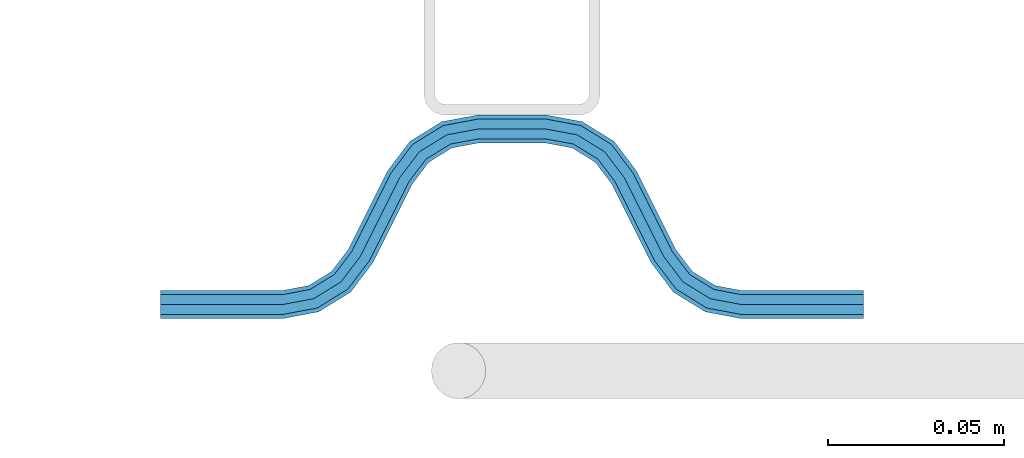
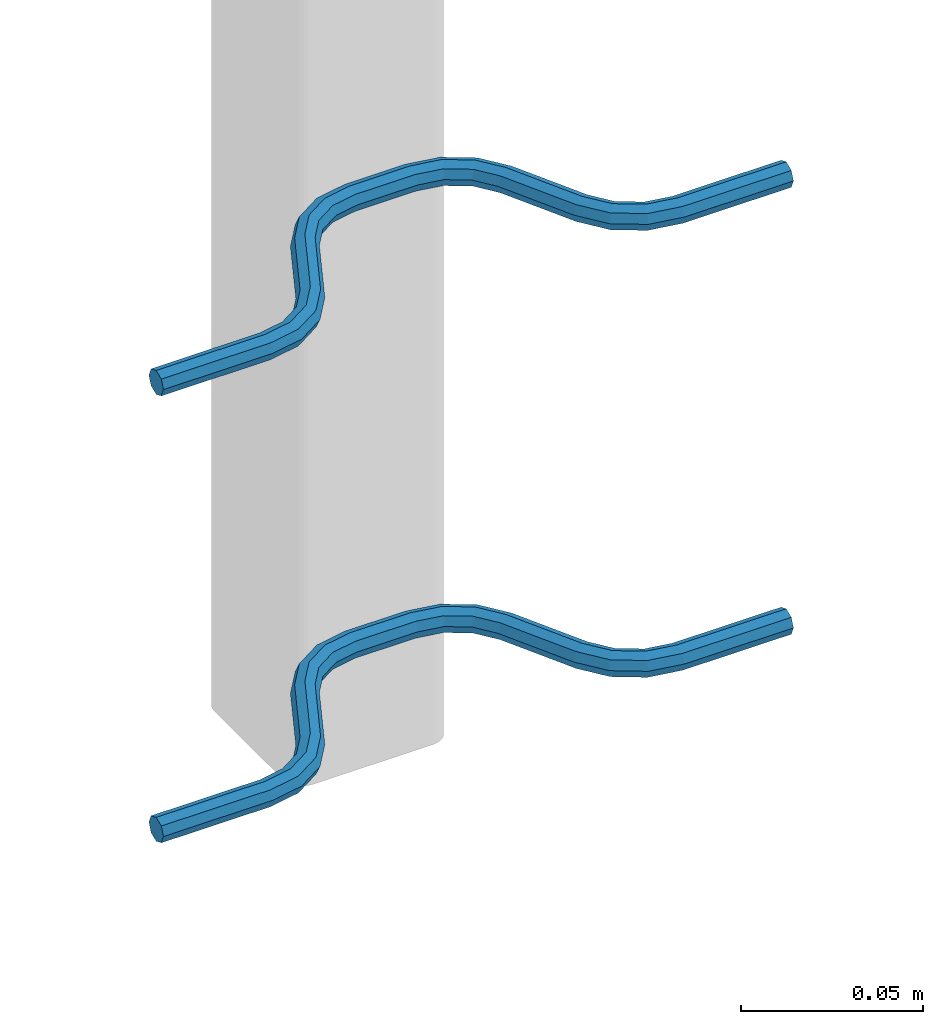
# One storey, part 5 of 5: 2 beams, 2 elements without a shape of their own.
"""IFC2X3 building model written with IfcOpenShell, lengths in millimetres."""

from ifc_helpers import new_model, si_unit, frame, origin_with_axes, place, context, subcontext, project, spatial, faceted_brep, material, type_object, element, aggregate, save


model = new_model("IFC2X3")

# Units and contexts
model_context = context("Model", 3, precision=1e-05, world=origin_with_axes())
body_context = subcontext(model_context, "Body", "Model", "MODEL_VIEW")
ifc_project = project(units=[si_unit("LENGTHUNIT", "METRE", prefix="MILLI"), si_unit("AREAUNIT", "SQUARE_METRE"), si_unit("VOLUMEUNIT", "CUBIC_METRE"), si_unit("MASSUNIT", "GRAM", prefix="KILO"), si_unit("TIMEUNIT", "SECOND"), si_unit("PLANEANGLEUNIT", "RADIAN"), si_unit("SOLIDANGLEUNIT", "STERADIAN"), si_unit("THERMODYNAMICTEMPERATUREUNIT", "DEGREE_CELSIUS"), si_unit("LUMINOUSINTENSITYUNIT", "LUMEN")], contexts=[model_context])

# Site, building, storey
site_placement = place(None, origin_with_axes())
site = spatial("IfcSite", under=ifc_project, at=site_placement, CompositionType="ELEMENT")
building_placement = place(site_placement, origin_with_axes())
building = spatial("IfcBuilding", under=site, at=building_placement, Name="Undefined", CompositionType="ELEMENT")
storey_placement = place(building_placement, origin_with_axes())
storey = spatial("IfcBuildingStorey", under=building, at=storey_placement, Name="Undefined", CompositionType="ELEMENT", Elevation=0.0)

# Assembly, beam
assembly_1_placement = place(storey_placement, origin_with_axes())
assembly_1 = element("IfcElementAssembly", 1, at=assembly_1_placement, inside=storey, Name="Steel Assembly", AssemblyPlace="NOTDEFINED", PredefinedType="NOTDEFINED")
ifc_material = material(Name="REBAR/A500HW")
beam_type = type_object("IfcBeamType", Name="D8", PredefinedType="NOTDEFINED")
beam_1_placement = place(assembly_1_placement, frame((38620.0028939469, 7595.92038402465, 2580.99992151562), z_axis=(0.0, 0.0, 1.0), x_axis=(-0.999999999544916, 3.01690000135643e-05, 0.0)))
beam_1 = element("IfcBeam", 2, at=beam_1_placement, type_object=beam_type, material=ifc_material, Name="AnchorRebar", ObjectType="D8", context=body_context, shape_type="Brep", body=[
    faceted_brep([(7.27595761418343e-12, -4.00000000000182, 0.0), (0.0, -2.82842712474667, -2.82842712474621), (34.5491497807379, -2.82842712464299, -2.82842712474621), (34.549149780345, -3.99999999990087, 0.0), (-7.27595761418343e-12, -1.81898940354586e-12, -4.0), (34.5491497807307, 1.02772901300341e-10, -4.0), (-1.45519152283669e-11, 2.82842712474485, -2.82842712474621), (34.5491497807234, 2.82842712484944, -2.82842712474621), (-2.18278728425503e-11, 3.99999999999909, 0.0), (34.5491497807234, 4.00000000010186, 0.0), (-1.45519152283669e-11, 2.82842712474485, 2.82842712474621), (34.5491497807234, 2.82842712484944, 2.82842712474621), (-7.27595761418343e-12, -1.81898940354586e-12, 4.0), (34.5491497807307, 1.02772901300341e-10, 4.0), (0.0, -2.82842712474667, 2.82842712474621), (34.5491497807379, -2.82842712464299, 2.82842712474621), (45.0102956729243, 2.04744769147965, 0.0), (44.5876751635515, 0.954756103194086, -2.82842712474621), (43.5673789981083, -1.68323474872432, -4.0), (42.5470828326725, -4.32122560063453, -2.82842712474621), (42.1244623233069, -5.41391718891373, 0.0), (42.5470828326725, -4.32122560063453, 2.82842712474621), (43.5673789981083, -1.68323474872432, 4.0), (44.5876751635515, 0.954756103194086, 2.82842712474621), (53.274424966643, -4.41395070837552, 2.82842712474621), (54.0627564232345, -3.54728092317691, 0.0), (51.3712244724884, -6.50627665790307, 4.0), (49.4680239783338, -8.59860260741789, 2.82842712474621), (48.6796925217277, -9.46527239261468, 0.0), (49.4680239783338, -8.59860260741789, -2.82842712474621), (51.3712244724884, -6.50627665790307, -4.0), (53.274424966643, -4.41395070837552, -2.82842712474621), (59.4396520594746, -12.5547498008682, 2.82842712474621), (60.4875387111679, -12.0308065146201, 0.0), (56.9098298930985, -13.8196607884374, 4.0), (54.3800077267297, -15.0845717760067, 2.82842712474621), (53.3321210758731, -15.6085150625322, 0.0), (54.3800077267297, -15.0845717760067, -2.82842712474621), (56.9098298930985, -13.8196607884374, -4.0), (59.4396520594746, -12.5547498008682, -2.82842712474621), (65.5603461600622, -37.4452503321163, -2.82842712474621), (64.5124595074158, -37.9691936177969, 0.0), (68.0901683264528, -36.1803393445689, -4.0), (70.6199904928435, -34.9154283570224, -2.82842712474621), (71.6678771445659, -34.3914850707852, 0.0), (70.6199904928435, -34.9154283570224, 2.82842712474621), (68.0901683264528, -36.1803393445689, 4.0), (65.5603461600622, -37.4452503321163, 2.82842712474621), (76.3203054721671, -40.5347275358472, 0.0), (75.5319740029881, -41.4013973096107, -2.82842712474621), (73.6287734785001, -43.493723231526, -4.0), (71.725572954012, -45.5860491534477, -2.82842712474621), (70.9372414848403, -46.4527189272058, 0.0), (71.725572954012, -45.5860491534477, 2.82842712474621), (73.6287734785001, -43.493723231526, 4.0), (75.5319740029881, -41.4013973096107, 2.82842712474621), (82.4529147876383, -45.678774301171, 2.82842712474621), (82.8755353286615, -44.5860827251427, 0.0), (81.4326185457467, -48.316765123519, 4.0), (80.4123223038623, -50.9547559458688, 2.82842712474621), (79.9897017628464, -52.0474475218998, 0.0), (80.4123223038623, -50.9547559458688, -2.82842712474621), (81.4326185457467, -48.316765123519, -4.0), (82.4529147876383, -45.678774301171, -2.82842712474621), (90.4508474761824, -47.1715730089909, 2.82842712474621), (90.4508475270486, -46.0000001337403, 0.0), (90.4508473533569, -50.0000001337421, 4.0), (90.4508472305388, -52.8284272584824, 2.82842712474621), (90.4508471810623, -54.0000001334192, 0.0), (90.4508472305388, -52.8284272584824, -2.82842712474621), (90.4508473533569, -50.0000001337421, -4.0), (90.4508474761824, -47.1715730089909, -2.82842712474621), (109.549147671314, -52.828428087013, -2.82842712474621), (109.549147618898, -54.0000009615114, 0.0), (109.549147794067, -50.0000009622654, -4.0), (109.549147916819, -47.1715738375196, -2.82842712474621), (109.549147967664, -46.0000009622663, 0.0), (109.549147916819, -47.1715738375196, 2.82842712474621), (109.549147794067, -50.0000009622654, 4.0), (109.549147671314, -52.828428087013, 2.82842712474621), (120.010293517989, -52.0474491371906, 0.0), (119.587673059206, -50.95475752935, 2.82842712474621), (118.567377015956, -48.3167666302052, 4.0), (117.547080972676, -45.6787757310622, 2.82842712474621), (117.124460513907, -44.5860841232252, 0.0), (117.547080972676, -45.6787757310622, -2.82842712474621), (118.567377015956, -48.3167666302052, -4.0), (119.587673059206, -50.95475752935, -2.82842712474621), (128.274423051225, -45.5860511742758, -2.82842712474621), (129.062754465151, -46.4527209982625, 0.0), (126.371222660033, -43.4937251311248, -4.0), (124.468022268848, -41.4013990879721, -2.82842712474621), (123.679690854893, -40.5347292639963, 0.0), (124.468022268848, -41.4013990879721, 2.82842712474621), (126.371222660033, -43.4937251311248, 4.0), (128.274423051225, -45.5860511742758, 2.82842712474621), (134.439650508539, -37.4452524573517, -2.82842712474621), (135.487537134875, -37.9691957980922, 0.0), (131.909828408097, -36.1803413379721, -4.0), (129.380006307656, -34.9154302185943, -2.82842712474621), (128.33211968324, -34.3914868777611, 0.0), (129.380006307656, -34.9154302185943, 2.82842712474621), (131.909828408097, -36.1803413379721, 4.0), (134.439650508539, -37.4452524573517, 2.82842712474621), (145.619991978034, -15.0845707426524, -2.82842712474621), (146.667878600529, -15.608514083453, 0.0), (143.090169877512, -13.8196596233502, -4.0), (140.560347776998, -12.554748504047, -2.82842712474621), (139.512461152575, -12.0308051632364, 0.0), (140.560347776998, -12.554748504047, 2.82842712474621), (143.090169877512, -13.8196596233502, 4.0), (145.619991978034, -15.0845707426524, 2.82842712474621), (151.320307204172, -9.46527190099096, 0.0), (150.531975777631, -8.59860208845839, 2.82842712474621), (148.628775356046, -6.50627607293518, 4.0), (146.725574934469, -4.41395005741288, 2.82842712474621), (145.937243507928, -3.54728024488213, 0.0), (146.725574934469, -4.41395005741288, -2.82842712474621), (148.628775356046, -6.50627607293518, -4.0), (150.531975777631, -8.59860208845839, -2.82842712474621), (157.452916713017, -4.32122546031951, -2.82842712474621), (157.875537203457, -5.4139170559065, 0.0), (156.432620593238, -1.68323459075327, -4.0), (155.41232447348, 0.954756278820241, -2.82842712474621), (154.989703983039, 2.04744787441359, 0.0), (155.41232447348, 0.954756278820241, 2.82842712474621), (156.432620593238, -1.68323459075327, 4.0), (157.452916713017, -4.32122546031951, 2.82842712474621), (165.450849406705, -2.8284271226612, -2.82842712474621), (165.450849408393, -3.9999999990614, 0.0), (165.45084940661, 2.0727384253405e-09, -4.0), (165.450849406516, 2.82842712681577, -2.82842712474621), (165.450849406494, 4.0000000020591, 0.0), (165.450849406516, 2.82842712681577, 2.82842712474621), (165.45084940661, 2.0727384253405e-09, 4.0), (165.450849406705, -2.8284271226612, 2.82842712474621), (200.000000089029, -2.82842712378351, -2.82842712474621), (200.000000089029, -3.99999999903866, 0.0), (200.000000089029, 9.61335899773985e-10, -4.0), (200.000000089021, 2.828427125708, -2.82842712474621), (200.000000089029, 4.00000000096134, 0.0), (200.000000089021, 2.828427125708, 2.82842712474621), (200.000000089029, 9.61335899773985e-10, 4.0), (200.000000089029, -2.82842712378351, 2.82842712474621)], [[[0, 1, 2, 3]], [[1, 4, 5, 2]], [[4, 6, 7, 5]], [[6, 8, 9, 7]], [[8, 10, 11, 9]], [[10, 12, 13, 11]], [[12, 14, 15, 13]], [[14, 0, 3, 15]], [[14, 12, 10, 8, 6, 4, 1, 0]], [[7, 9, 16, 17]], [[5, 7, 17, 18]], [[2, 5, 18, 19]], [[3, 2, 19, 20]], [[15, 3, 20, 21]], [[13, 15, 21, 22]], [[11, 13, 22, 23]], [[9, 11, 23, 16]], [[23, 24, 25, 16]], [[22, 26, 24, 23]], [[21, 27, 26, 22]], [[20, 28, 27, 21]], [[19, 29, 28, 20]], [[18, 30, 29, 19]], [[17, 31, 30, 18]], [[16, 25, 31, 17]], [[24, 32, 33, 25]], [[26, 34, 32, 24]], [[27, 35, 34, 26]], [[28, 36, 35, 27]], [[29, 37, 36, 28]], [[30, 38, 37, 29]], [[31, 39, 38, 30]], [[25, 33, 39, 31]], [[36, 37, 40, 41]], [[37, 38, 42, 40]], [[38, 39, 43, 42]], [[39, 33, 44, 43]], [[33, 32, 45, 44]], [[32, 34, 46, 45]], [[34, 35, 47, 46]], [[35, 36, 41, 47]], [[43, 44, 48, 49]], [[42, 43, 49, 50]], [[40, 42, 50, 51]], [[41, 40, 51, 52]], [[47, 41, 52, 53]], [[46, 47, 53, 54]], [[45, 46, 54, 55]], [[44, 45, 55, 48]], [[55, 56, 57, 48]], [[54, 58, 56, 55]], [[53, 59, 58, 54]], [[52, 60, 59, 53]], [[51, 61, 60, 52]], [[50, 62, 61, 51]], [[49, 63, 62, 50]], [[48, 57, 63, 49]], [[56, 64, 65, 57]], [[58, 66, 64, 56]], [[59, 67, 66, 58]], [[60, 68, 67, 59]], [[61, 69, 68, 60]], [[62, 70, 69, 61]], [[63, 71, 70, 62]], [[57, 65, 71, 63]], [[68, 69, 72, 73]], [[69, 70, 74, 72]], [[70, 71, 75, 74]], [[71, 65, 76, 75]], [[65, 64, 77, 76]], [[64, 66, 78, 77]], [[66, 67, 79, 78]], [[67, 68, 73, 79]], [[79, 73, 80, 81]], [[78, 79, 81, 82]], [[77, 78, 82, 83]], [[76, 77, 83, 84]], [[75, 76, 84, 85]], [[74, 75, 85, 86]], [[72, 74, 86, 87]], [[73, 72, 87, 80]], [[87, 88, 89, 80]], [[86, 90, 88, 87]], [[85, 91, 90, 86]], [[84, 92, 91, 85]], [[83, 93, 92, 84]], [[82, 94, 93, 83]], [[81, 95, 94, 82]], [[80, 89, 95, 81]], [[88, 96, 97, 89]], [[90, 98, 96, 88]], [[91, 99, 98, 90]], [[92, 100, 99, 91]], [[93, 101, 100, 92]], [[94, 102, 101, 93]], [[95, 103, 102, 94]], [[89, 97, 103, 95]], [[97, 96, 104, 105]], [[96, 98, 106, 104]], [[98, 99, 107, 106]], [[99, 100, 108, 107]], [[100, 101, 109, 108]], [[101, 102, 110, 109]], [[102, 103, 111, 110]], [[103, 97, 105, 111]], [[111, 105, 112, 113]], [[110, 111, 113, 114]], [[109, 110, 114, 115]], [[108, 109, 115, 116]], [[107, 108, 116, 117]], [[106, 107, 117, 118]], [[104, 106, 118, 119]], [[105, 104, 119, 112]], [[119, 120, 121, 112]], [[118, 122, 120, 119]], [[117, 123, 122, 118]], [[116, 124, 123, 117]], [[115, 125, 124, 116]], [[114, 126, 125, 115]], [[113, 127, 126, 114]], [[112, 121, 127, 113]], [[120, 128, 129, 121]], [[122, 130, 128, 120]], [[123, 131, 130, 122]], [[124, 132, 131, 123]], [[125, 133, 132, 124]], [[126, 134, 133, 125]], [[127, 135, 134, 126]], [[121, 129, 135, 127]], [[129, 128, 136, 137]], [[128, 130, 138, 136]], [[130, 131, 139, 138]], [[131, 132, 140, 139]], [[132, 133, 141, 140]], [[133, 134, 142, 141]], [[134, 135, 143, 142]], [[135, 129, 137, 143]], [[138, 139, 140, 141, 142, 143, 137, 136]]]),
])
aggregate(assembly_1, [beam_1])

assembly_2_placement = place(storey_placement, origin_with_axes())
assembly_2 = element("IfcElementAssembly", 3, at=assembly_2_placement, inside=storey, Name="Steel Assembly", AssemblyPlace="NOTDEFINED", PredefinedType="NOTDEFINED")
beam_2_placement = place(assembly_2_placement, frame((38620.0028939469, 7595.92038402465, 2430.99992151562), z_axis=(0.0, 0.0, 1.0), x_axis=(-0.999999999544916, 3.01690000135643e-05, 0.0)))
beam_2 = element("IfcBeam", 4, at=beam_2_placement, type_object=beam_type, material=ifc_material, Name="AnchorRebar", ObjectType="D8", context=body_context, shape_type="Brep", body=[
    faceted_brep([(7.27595761418343e-12, -4.00000000000182, 0.0), (0.0, -2.82842712474667, -2.82842712474621), (34.5491497807379, -2.82842712464299, -2.82842712474621), (34.549149780345, -3.99999999990087, 0.0), (-7.27595761418343e-12, -1.81898940354586e-12, -4.0), (34.5491497807307, 1.02772901300341e-10, -4.0), (-1.45519152283669e-11, 2.82842712474485, -2.82842712474621), (34.5491497807234, 2.82842712484944, -2.82842712474621), (-2.18278728425503e-11, 3.99999999999909, 0.0), (34.5491497807234, 4.00000000010186, 0.0), (-1.45519152283669e-11, 2.82842712474485, 2.82842712474621), (34.5491497807234, 2.82842712484944, 2.82842712474621), (-7.27595761418343e-12, -1.81898940354586e-12, 4.0), (34.5491497807307, 1.02772901300341e-10, 4.0), (0.0, -2.82842712474667, 2.82842712474621), (34.5491497807379, -2.82842712464299, 2.82842712474621), (45.0102956729243, 2.04744769147965, 0.0), (44.5876751635515, 0.954756103194086, -2.82842712474621), (43.5673789981083, -1.68323474872432, -4.0), (42.5470828326725, -4.32122560063453, -2.82842712474621), (42.1244623233069, -5.41391718891373, 0.0), (42.5470828326725, -4.32122560063453, 2.82842712474621), (43.5673789981083, -1.68323474872432, 4.0), (44.5876751635515, 0.954756103194086, 2.82842712474621), (53.274424966643, -4.41395070837552, 2.82842712474621), (54.0627564232345, -3.54728092317691, 0.0), (51.3712244724884, -6.50627665790307, 4.0), (49.4680239783338, -8.59860260741789, 2.82842712474621), (48.6796925217277, -9.46527239261468, 0.0), (49.4680239783338, -8.59860260741789, -2.82842712474621), (51.3712244724884, -6.50627665790307, -4.0), (53.274424966643, -4.41395070837552, -2.82842712474621), (59.4396520594746, -12.5547498008682, 2.82842712474621), (60.4875387111679, -12.0308065146201, 0.0), (56.9098298930985, -13.8196607884374, 4.0), (54.3800077267297, -15.0845717760067, 2.82842712474621), (53.3321210758731, -15.6085150625322, 0.0), (54.3800077267297, -15.0845717760067, -2.82842712474621), (56.9098298930985, -13.8196607884374, -4.0), (59.4396520594746, -12.5547498008682, -2.82842712474621), (65.5603461600622, -37.4452503321163, -2.82842712474621), (64.5124595074158, -37.9691936177969, 0.0), (68.0901683264528, -36.1803393445689, -4.0), (70.6199904928435, -34.9154283570224, -2.82842712474621), (71.6678771445659, -34.3914850707852, 0.0), (70.6199904928435, -34.9154283570224, 2.82842712474621), (68.0901683264528, -36.1803393445689, 4.0), (65.5603461600622, -37.4452503321163, 2.82842712474621), (76.3203054721671, -40.5347275358472, 0.0), (75.5319740029881, -41.4013973096107, -2.82842712474621), (73.6287734785001, -43.493723231526, -4.0), (71.725572954012, -45.5860491534477, -2.82842712474621), (70.9372414848403, -46.4527189272058, 0.0), (71.725572954012, -45.5860491534477, 2.82842712474621), (73.6287734785001, -43.493723231526, 4.0), (75.5319740029881, -41.4013973096107, 2.82842712474621), (82.4529147876383, -45.678774301171, 2.82842712474621), (82.8755353286615, -44.5860827251427, 0.0), (81.4326185457467, -48.316765123519, 4.0), (80.4123223038623, -50.9547559458688, 2.82842712474621), (79.9897017628464, -52.0474475218998, 0.0), (80.4123223038623, -50.9547559458688, -2.82842712474621), (81.4326185457467, -48.316765123519, -4.0), (82.4529147876383, -45.678774301171, -2.82842712474621), (90.4508474761824, -47.1715730089909, 2.82842712474621), (90.4508475270486, -46.0000001337403, 0.0), (90.4508473533569, -50.0000001337421, 4.0), (90.4508472305388, -52.8284272584824, 2.82842712474621), (90.4508471810623, -54.0000001334192, 0.0), (90.4508472305388, -52.8284272584824, -2.82842712474621), (90.4508473533569, -50.0000001337421, -4.0), (90.4508474761824, -47.1715730089909, -2.82842712474621), (109.549147671314, -52.828428087013, -2.82842712474621), (109.549147618898, -54.0000009615114, 0.0), (109.549147794067, -50.0000009622654, -4.0), (109.549147916819, -47.1715738375196, -2.82842712474621), (109.549147967664, -46.0000009622663, 0.0), (109.549147916819, -47.1715738375196, 2.82842712474621), (109.549147794067, -50.0000009622654, 4.0), (109.549147671314, -52.828428087013, 2.82842712474621), (120.010293517989, -52.0474491371906, 0.0), (119.587673059206, -50.95475752935, 2.82842712474621), (118.567377015956, -48.3167666302052, 4.0), (117.547080972676, -45.6787757310622, 2.82842712474621), (117.124460513907, -44.5860841232252, 0.0), (117.547080972676, -45.6787757310622, -2.82842712474621), (118.567377015956, -48.3167666302052, -4.0), (119.587673059206, -50.95475752935, -2.82842712474621), (128.274423051225, -45.5860511742758, -2.82842712474621), (129.062754465151, -46.4527209982625, 0.0), (126.371222660033, -43.4937251311248, -4.0), (124.468022268848, -41.4013990879721, -2.82842712474621), (123.679690854893, -40.5347292639963, 0.0), (124.468022268848, -41.4013990879721, 2.82842712474621), (126.371222660033, -43.4937251311248, 4.0), (128.274423051225, -45.5860511742758, 2.82842712474621), (134.439650508539, -37.4452524573517, -2.82842712474621), (135.487537134875, -37.9691957980922, 0.0), (131.909828408097, -36.1803413379721, -4.0), (129.380006307656, -34.9154302185943, -2.82842712474621), (128.33211968324, -34.3914868777611, 0.0), (129.380006307656, -34.9154302185943, 2.82842712474621), (131.909828408097, -36.1803413379721, 4.0), (134.439650508539, -37.4452524573517, 2.82842712474621), (145.619991978034, -15.0845707426524, -2.82842712474621), (146.667878600529, -15.608514083453, 0.0), (143.090169877512, -13.8196596233502, -4.0), (140.560347776998, -12.554748504047, -2.82842712474621), (139.512461152575, -12.0308051632364, 0.0), (140.560347776998, -12.554748504047, 2.82842712474621), (143.090169877512, -13.8196596233502, 4.0), (145.619991978034, -15.0845707426524, 2.82842712474621), (151.320307204172, -9.46527190099096, 0.0), (150.531975777631, -8.59860208845839, 2.82842712474621), (148.628775356046, -6.50627607293518, 4.0), (146.725574934469, -4.41395005741288, 2.82842712474621), (145.937243507928, -3.54728024488213, 0.0), (146.725574934469, -4.41395005741288, -2.82842712474621), (148.628775356046, -6.50627607293518, -4.0), (150.531975777631, -8.59860208845839, -2.82842712474621), (157.452916713017, -4.32122546031951, -2.82842712474621), (157.875537203457, -5.4139170559065, 0.0), (156.432620593238, -1.68323459075327, -4.0), (155.41232447348, 0.954756278820241, -2.82842712474621), (154.989703983039, 2.04744787441359, 0.0), (155.41232447348, 0.954756278820241, 2.82842712474621), (156.432620593238, -1.68323459075327, 4.0), (157.452916713017, -4.32122546031951, 2.82842712474621), (165.450849406705, -2.8284271226612, -2.82842712474621), (165.450849408393, -3.9999999990614, 0.0), (165.45084940661, 2.0727384253405e-09, -4.0), (165.450849406516, 2.82842712681577, -2.82842712474621), (165.450849406494, 4.0000000020591, 0.0), (165.450849406516, 2.82842712681577, 2.82842712474621), (165.45084940661, 2.0727384253405e-09, 4.0), (165.450849406705, -2.8284271226612, 2.82842712474621), (200.000000089029, -2.82842712378351, -2.82842712474621), (200.000000089029, -3.99999999903866, 0.0), (200.000000089029, 9.61335899773985e-10, -4.0), (200.000000089021, 2.828427125708, -2.82842712474621), (200.000000089029, 4.00000000096134, 0.0), (200.000000089021, 2.828427125708, 2.82842712474621), (200.000000089029, 9.61335899773985e-10, 4.0), (200.000000089029, -2.82842712378351, 2.82842712474621)], [[[0, 1, 2, 3]], [[1, 4, 5, 2]], [[4, 6, 7, 5]], [[6, 8, 9, 7]], [[8, 10, 11, 9]], [[10, 12, 13, 11]], [[12, 14, 15, 13]], [[14, 0, 3, 15]], [[14, 12, 10, 8, 6, 4, 1, 0]], [[7, 9, 16, 17]], [[5, 7, 17, 18]], [[2, 5, 18, 19]], [[3, 2, 19, 20]], [[15, 3, 20, 21]], [[13, 15, 21, 22]], [[11, 13, 22, 23]], [[9, 11, 23, 16]], [[23, 24, 25, 16]], [[22, 26, 24, 23]], [[21, 27, 26, 22]], [[20, 28, 27, 21]], [[19, 29, 28, 20]], [[18, 30, 29, 19]], [[17, 31, 30, 18]], [[16, 25, 31, 17]], [[24, 32, 33, 25]], [[26, 34, 32, 24]], [[27, 35, 34, 26]], [[28, 36, 35, 27]], [[29, 37, 36, 28]], [[30, 38, 37, 29]], [[31, 39, 38, 30]], [[25, 33, 39, 31]], [[36, 37, 40, 41]], [[37, 38, 42, 40]], [[38, 39, 43, 42]], [[39, 33, 44, 43]], [[33, 32, 45, 44]], [[32, 34, 46, 45]], [[34, 35, 47, 46]], [[35, 36, 41, 47]], [[43, 44, 48, 49]], [[42, 43, 49, 50]], [[40, 42, 50, 51]], [[41, 40, 51, 52]], [[47, 41, 52, 53]], [[46, 47, 53, 54]], [[45, 46, 54, 55]], [[44, 45, 55, 48]], [[55, 56, 57, 48]], [[54, 58, 56, 55]], [[53, 59, 58, 54]], [[52, 60, 59, 53]], [[51, 61, 60, 52]], [[50, 62, 61, 51]], [[49, 63, 62, 50]], [[48, 57, 63, 49]], [[56, 64, 65, 57]], [[58, 66, 64, 56]], [[59, 67, 66, 58]], [[60, 68, 67, 59]], [[61, 69, 68, 60]], [[62, 70, 69, 61]], [[63, 71, 70, 62]], [[57, 65, 71, 63]], [[68, 69, 72, 73]], [[69, 70, 74, 72]], [[70, 71, 75, 74]], [[71, 65, 76, 75]], [[65, 64, 77, 76]], [[64, 66, 78, 77]], [[66, 67, 79, 78]], [[67, 68, 73, 79]], [[79, 73, 80, 81]], [[78, 79, 81, 82]], [[77, 78, 82, 83]], [[76, 77, 83, 84]], [[75, 76, 84, 85]], [[74, 75, 85, 86]], [[72, 74, 86, 87]], [[73, 72, 87, 80]], [[87, 88, 89, 80]], [[86, 90, 88, 87]], [[85, 91, 90, 86]], [[84, 92, 91, 85]], [[83, 93, 92, 84]], [[82, 94, 93, 83]], [[81, 95, 94, 82]], [[80, 89, 95, 81]], [[88, 96, 97, 89]], [[90, 98, 96, 88]], [[91, 99, 98, 90]], [[92, 100, 99, 91]], [[93, 101, 100, 92]], [[94, 102, 101, 93]], [[95, 103, 102, 94]], [[89, 97, 103, 95]], [[97, 96, 104, 105]], [[96, 98, 106, 104]], [[98, 99, 107, 106]], [[99, 100, 108, 107]], [[100, 101, 109, 108]], [[101, 102, 110, 109]], [[102, 103, 111, 110]], [[103, 97, 105, 111]], [[111, 105, 112, 113]], [[110, 111, 113, 114]], [[109, 110, 114, 115]], [[108, 109, 115, 116]], [[107, 108, 116, 117]], [[106, 107, 117, 118]], [[104, 106, 118, 119]], [[105, 104, 119, 112]], [[119, 120, 121, 112]], [[118, 122, 120, 119]], [[117, 123, 122, 118]], [[116, 124, 123, 117]], [[115, 125, 124, 116]], [[114, 126, 125, 115]], [[113, 127, 126, 114]], [[112, 121, 127, 113]], [[120, 128, 129, 121]], [[122, 130, 128, 120]], [[123, 131, 130, 122]], [[124, 132, 131, 123]], [[125, 133, 132, 124]], [[126, 134, 133, 125]], [[127, 135, 134, 126]], [[121, 129, 135, 127]], [[129, 128, 136, 137]], [[128, 130, 138, 136]], [[130, 131, 139, 138]], [[131, 132, 140, 139]], [[132, 133, 141, 140]], [[133, 134, 142, 141]], [[134, 135, 143, 142]], [[135, 129, 137, 143]], [[138, 139, 140, 141, 142, 143, 137, 136]]]),
])
aggregate(assembly_2, [beam_2])

save(model, "model.ifc")
